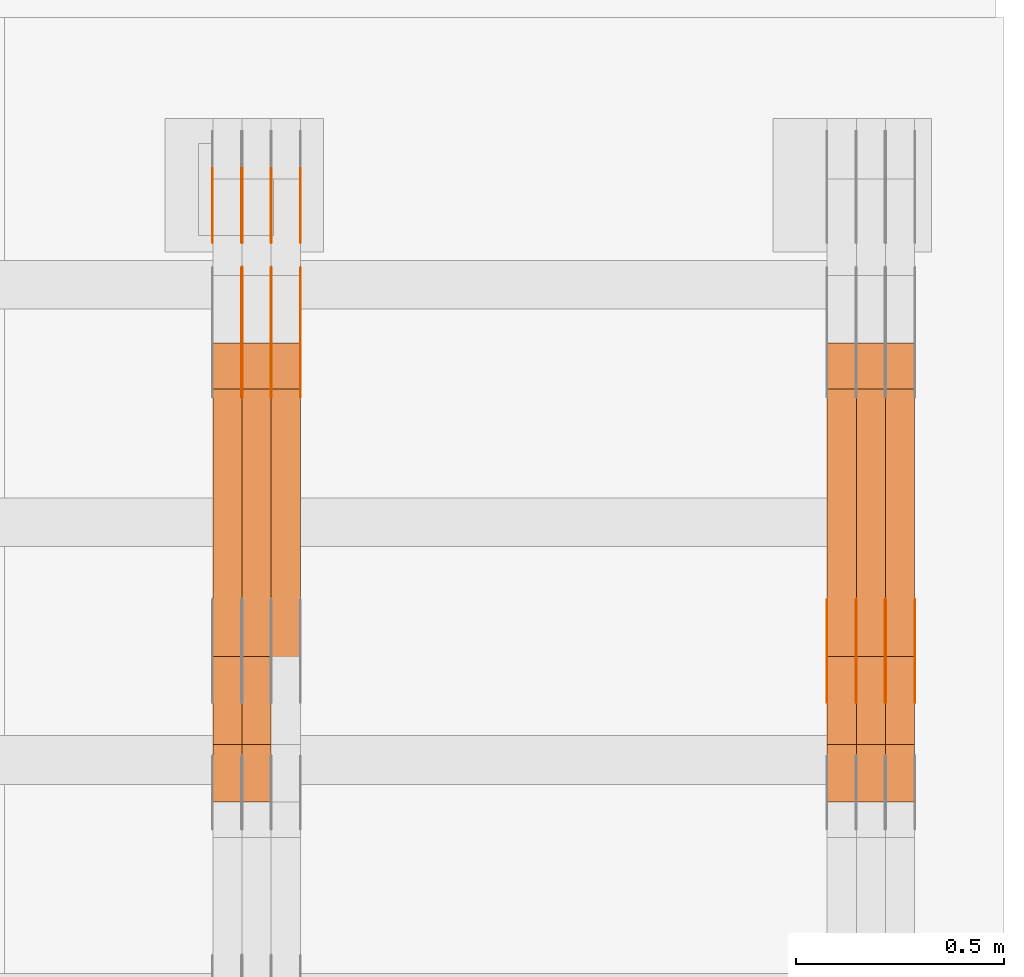
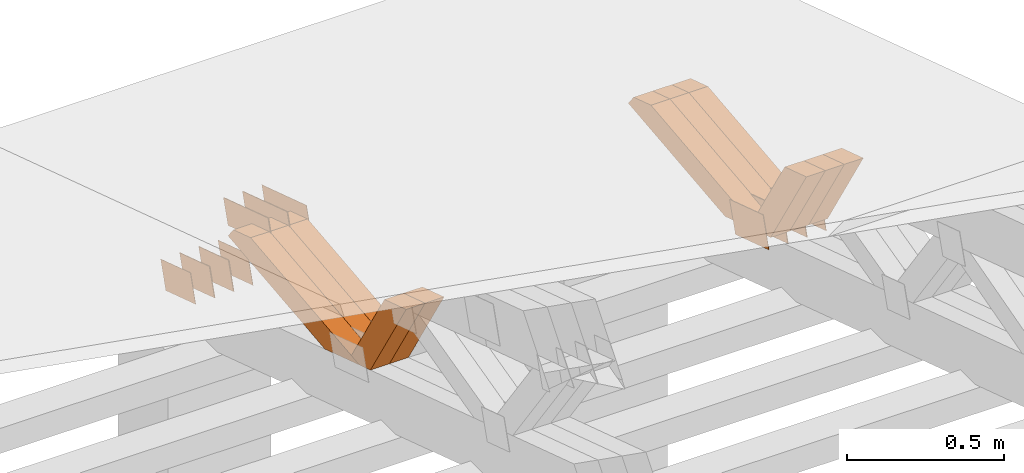
# One storey, part 375 of 385: 28 proxies.
"""IFC2X3 building model written with IfcOpenShell, lengths in millimetres."""

from ifc_helpers import new_model, entity, si_unit, converted_unit, derived_unit, direction, frame, origin, place, context, subcontext, project, spatial, polyline, outline, extrude, source, transform, mapped, material, type_object, type_shapes, element, save


model = new_model("IFC2X3")

# Units and contexts
model_context = context("Model", 3, precision=0.01, world=origin(), true_north=direction((6.12303176911189e-17, 1.0)))
body_context = subcontext(model_context, "Body", "Model", "MODEL_VIEW")
ifc_project = project(units=[si_unit("LENGTHUNIT", "METRE", prefix="MILLI"), si_unit("AREAUNIT", "SQUARE_METRE"), si_unit("VOLUMEUNIT", "CUBIC_METRE"), converted_unit("PLANEANGLEUNIT", "DEGREE", entity("IfcRatioMeasure", 0.0174532925199433), si_unit("PLANEANGLEUNIT", "RADIAN"), dimensions=[0, 0, 0, 0, 0, 0, 0]), si_unit("MASSUNIT", "GRAM", prefix="KILO"), derived_unit("MASSDENSITYUNIT", [(si_unit("MASSUNIT", "GRAM", prefix="KILO"), 1), (si_unit("LENGTHUNIT", "METRE"), -3)]), si_unit("TIMEUNIT", "SECOND"), si_unit("FREQUENCYUNIT", "HERTZ"), si_unit("THERMODYNAMICTEMPERATUREUNIT", "DEGREE_CELSIUS"), derived_unit("THERMALTRANSMITTANCEUNIT", [(si_unit("MASSUNIT", "GRAM", prefix="KILO"), 1), (si_unit("THERMODYNAMICTEMPERATUREUNIT", "KELVIN"), -1), (si_unit("TIMEUNIT", "SECOND"), -3)]), derived_unit("VOLUMETRICFLOWRATEUNIT", [(si_unit("LENGTHUNIT", "METRE"), 3), (si_unit("TIMEUNIT", "SECOND"), -1)]), si_unit("ELECTRICCURRENTUNIT", "AMPERE"), si_unit("ELECTRICVOLTAGEUNIT", "VOLT"), si_unit("POWERUNIT", "WATT"), si_unit("FORCEUNIT", "NEWTON", prefix="KILO"), si_unit("ILLUMINANCEUNIT", "LUX"), si_unit("LUMINOUSFLUXUNIT", "LUMEN"), si_unit("LUMINOUSINTENSITYUNIT", "CANDELA"), derived_unit("USERDEFINED", [(si_unit("MASSUNIT", "GRAM", prefix="KILO"), -1), (si_unit("LENGTHUNIT", "METRE"), -2), (si_unit("TIMEUNIT", "SECOND"), 3), (si_unit("LUMINOUSFLUXUNIT", "LUMEN"), 1)]), derived_unit("LINEARVELOCITYUNIT", [(si_unit("LENGTHUNIT", "METRE"), 1), (si_unit("TIMEUNIT", "SECOND"), -1)]), si_unit("PRESSUREUNIT", "PASCAL"), derived_unit("USERDEFINED", [(si_unit("LENGTHUNIT", "METRE"), -2), (si_unit("MASSUNIT", "GRAM", prefix="KILO"), 1), (si_unit("TIMEUNIT", "SECOND"), -2)])], contexts=[model_context])

# Site, building, storey
site_placement = place(None, origin())
site = spatial("IfcSite", under=ifc_project, at=site_placement, CompositionType="ELEMENT")
building_placement = place(site_placement, origin())
building = spatial("IfcBuilding", under=site, at=building_placement, CompositionType="ELEMENT")
storey_placement = place(building_placement, origin())
storey = spatial("IfcBuildingStorey", under=building, at=storey_placement, Name="Default", CompositionType="ELEMENT", Elevation=0.0)

# Proxies
ifc_material_1 = material(Name="IfcSurfaceStyle #607276")
building_element_proxy_type_1 = type_object("IfcBuildingElementProxyType", PredefinedType="NOTDEFINED", material=ifc_material_1)
shared_shape_1 = source(origin(), body_context, "Body", "SweptSolid", [
    extrude(outline(polyline([(-112.50003853564, -60.0000121429077), (112.50002982902, -60.0000121429077), (112.500043250865, 60.0000121429077), (-112.500034544245, 60.0000121429077), (-112.50003853564, -60.0000121429077)])), frame((112.500056021398, 60.0000121429077, 0.0), z_axis=(0.0, 0.0, 1.0), x_axis=(-1.0, 0.0, 0.0)), (0.0, 0.0, 1.0), 1.3),
])
type_shapes(building_element_proxy_type_1, [shared_shape_1])
proxy_1_placement = place(building_placement, frame((49861.3, 25310.2182710494, 430.675738123044), z_axis=(-1.0, 0.0, 0.0), x_axis=(0.0, -0.951056516295124, 0.309016994375039)))
element("IfcBuildingElementProxy", 1, at=proxy_1_placement, inside=storey, type_object=building_element_proxy_type_1, material=ifc_material_1, context=body_context, shape_type="MappedRepresentation", body=[
    mapped(shared_shape_1, transform((0.0, 0.0, 0.0), scale=1.0)),
])
ifc_material_2 = material(Name="IfcSurfaceStyle #607219")
building_element_proxy_type_2 = type_object("IfcBuildingElementProxyType", PredefinedType="NOTDEFINED", material=ifc_material_2)
shared_shape_2 = source(origin(), body_context, "Body", "SweptSolid", [
    extrude(outline(polyline([(-112.50003853564, -60.0000121429077), (112.50002982902, -60.0000121429077), (112.500043250865, 60.0000121429077), (-112.500034544245, 60.0000121429077), (-112.50003853564, -60.0000121429077)])), frame((112.500056021398, 60.0000121429077, 0.0), z_axis=(0.0, 0.0, 1.0), x_axis=(-1.0, 0.0, 0.0)), (0.0, 0.0, 1.0), 1.3),
])
type_shapes(building_element_proxy_type_2, [shared_shape_2])
proxy_2_placement = place(building_placement, frame((49790.0, 25310.2182710494, 430.675738123044), z_axis=(-1.0, 0.0, 0.0), x_axis=(0.0, -0.951056516295124, 0.309016994375039)))
element("IfcBuildingElementProxy", 2, at=proxy_2_placement, inside=storey, type_object=building_element_proxy_type_2, material=ifc_material_2, context=body_context, shape_type="MappedRepresentation", body=[
    mapped(shared_shape_2, transform((0.0, 0.0, 0.0), scale=1.0)),
])
ifc_material_3 = material(Name="IfcSurfaceStyle #607162")
building_element_proxy_type_3 = type_object("IfcBuildingElementProxyType", PredefinedType="NOTDEFINED", material=ifc_material_3)
shared_shape_3 = source(origin(), body_context, "Body", "SweptSolid", [
    extrude(outline(polyline([(-112.50003853564, -60.0000121429077), (112.50002982902, -60.0000121429077), (112.500043250865, 60.0000121429077), (-112.500034544245, 60.0000121429077), (-112.50003853564, -60.0000121429077)])), frame((112.500056021398, 60.0000121429077, 0.0), z_axis=(0.0, 0.0, 1.0), x_axis=(-1.0, 0.0, 0.0)), (0.0, 0.0, 1.0), 1.3),
])
type_shapes(building_element_proxy_type_3, [shared_shape_3])
proxy_3_placement = place(building_placement, frame((49791.3, 25310.2182710494, 430.675738123044), z_axis=(-1.0, 0.0, 0.0), x_axis=(0.0, -0.951056516295124, 0.309016994375039)))
element("IfcBuildingElementProxy", 3, at=proxy_3_placement, inside=storey, type_object=building_element_proxy_type_3, material=ifc_material_3, context=body_context, shape_type="MappedRepresentation", body=[
    mapped(shared_shape_3, transform((0.0, 0.0, 0.0), scale=1.0)),
])
ifc_material_4 = material(Name="IfcSurfaceStyle #607105")
building_element_proxy_type_4 = type_object("IfcBuildingElementProxyType", PredefinedType="NOTDEFINED", material=ifc_material_4)
shared_shape_4 = source(origin(), body_context, "Body", "SweptSolid", [
    extrude(outline(polyline([(-112.50003853564, -60.0000121429077), (112.50002982902, -60.0000121429077), (112.500043250865, 60.0000121429077), (-112.500034544245, 60.0000121429077), (-112.50003853564, -60.0000121429077)])), frame((112.500056021398, 60.0000121429077, 0.0), z_axis=(0.0, 0.0, 1.0), x_axis=(-1.0, 0.0, 0.0)), (0.0, 0.0, 1.0), 1.29999999999998),
])
type_shapes(building_element_proxy_type_4, [shared_shape_4])
proxy_4_placement = place(building_placement, frame((49720.0, 25310.2182710494, 430.675738123044), z_axis=(-1.0, 0.0, 0.0), x_axis=(0.0, -0.951056516295124, 0.309016994375039)))
element("IfcBuildingElementProxy", 4, at=proxy_4_placement, inside=storey, type_object=building_element_proxy_type_4, material=ifc_material_4, context=body_context, shape_type="MappedRepresentation", body=[
    mapped(shared_shape_4, transform((0.0, 0.0, 0.0), scale=1.0)),
])
ifc_material_5 = material(Name="IfcSurfaceStyle #607048")
building_element_proxy_type_5 = type_object("IfcBuildingElementProxyType", PredefinedType="NOTDEFINED", material=ifc_material_5)
shared_shape_5 = source(origin(), body_context, "Body", "SweptSolid", [
    extrude(outline(polyline([(-112.50003853564, -60.0000121429077), (112.50002982902, -60.0000121429077), (112.500043250865, 60.0000121429077), (-112.500034544245, 60.0000121429077), (-112.50003853564, -60.0000121429077)])), frame((112.500056021398, 60.0000121429077, 0.0), z_axis=(0.0, 0.0, 1.0), x_axis=(-1.0, 0.0, 0.0)), (0.0, 0.0, 1.0), 1.29999999999998),
])
type_shapes(building_element_proxy_type_5, [shared_shape_5])
proxy_5_placement = place(building_placement, frame((49721.3, 25310.2182710494, 430.675738123044), z_axis=(-1.0, 0.0, 0.0), x_axis=(0.0, -0.951056516295124, 0.309016994375039)))
element("IfcBuildingElementProxy", 5, at=proxy_5_placement, inside=storey, type_object=building_element_proxy_type_5, material=ifc_material_5, context=body_context, shape_type="MappedRepresentation", body=[
    mapped(shared_shape_5, transform((0.0, 0.0, 0.0), scale=1.0)),
])
ifc_material_6 = material(Name="IfcSurfaceStyle #606991")
building_element_proxy_type_6 = type_object("IfcBuildingElementProxyType", PredefinedType="NOTDEFINED", material=ifc_material_6)
shared_shape_6 = source(origin(), body_context, "Body", "SweptSolid", [
    extrude(outline(polyline([(-112.50003853564, -60.0000121429077), (112.50002982902, -60.0000121429077), (112.500043250865, 60.0000121429077), (-112.500034544245, 60.0000121429077), (-112.50003853564, -60.0000121429077)])), frame((112.500056021398, 60.0000121429077, 0.0), z_axis=(0.0, 0.0, 1.0), x_axis=(-1.0, 0.0, 0.0)), (0.0, 0.0, 1.0), 1.29999999999999),
])
type_shapes(building_element_proxy_type_6, [shared_shape_6])
proxy_6_placement = place(building_placement, frame((49650.0, 25310.2182710494, 430.675738123044), z_axis=(-1.0, 0.0, 0.0), x_axis=(0.0, -0.951056516295124, 0.309016994375039)))
element("IfcBuildingElementProxy", 6, at=proxy_6_placement, inside=storey, type_object=building_element_proxy_type_6, material=ifc_material_6, context=body_context, shape_type="MappedRepresentation", body=[
    mapped(shared_shape_6, transform((0.0, 0.0, 0.0), scale=1.0)),
])
ifc_material_7 = material(Name="IfcSurfaceStyle #595234")
building_element_proxy_type_7 = type_object("IfcBuildingElementProxyType", Name="T2-W31 595232", PredefinedType="NOTDEFINED", material=ifc_material_7)
shared_shape_7 = source(origin(), body_context, "Body", "SweptSolid", [
    extrude(outline(polyline([(-201.245318299844, -47.5000121670808), (204.413774229459, -47.5000121670808), (182.034306640891, 5.35692244583164e-05), (126.70380769348, 47.4999853824686), (-311.906570263987, 47.4999853824686), (-201.245318299844, -47.5000121670808)])), frame((204.413774229459, 47.5002684334588, 0.0), z_axis=(0.0, 0.0, 1.0), x_axis=(-1.0, 0.0, 0.0)), (0.0, 0.0, 1.0), 70.0),
])
type_shapes(building_element_proxy_type_7, [shared_shape_7])
proxy_7_placement = place(building_placement, frame((49860.0, 25127.5652647985, 487.27008059185), z_axis=(-1.0, 0.0, 0.0), x_axis=(0.0, -0.520333970303023, 0.853962855953755)))
element("IfcBuildingElementProxy", 7, at=proxy_7_placement, inside=storey, type_object=building_element_proxy_type_7, material=ifc_material_7, Name="T2-W31", context=body_context, shape_type="MappedRepresentation", body=[
    mapped(shared_shape_7, transform((0.0, 0.0, 0.0), scale=1.0)),
])
ifc_material_8 = material(Name="IfcSurfaceStyle #595168")
building_element_proxy_type_8 = type_object("IfcBuildingElementProxyType", Name="T2-W31 595166", PredefinedType="NOTDEFINED", material=ifc_material_8)
shared_shape_8 = source(origin(), body_context, "Body", "SweptSolid", [
    extrude(outline(polyline([(-201.245318299844, -47.5000121670808), (204.413774229459, -47.5000121670808), (182.034306640891, 5.35692244583164e-05), (126.70380769348, 47.4999853824686), (-311.906570263987, 47.4999853824686), (-201.245318299844, -47.5000121670808)])), frame((204.413774229459, 47.5002684334588, 0.0), z_axis=(0.0, 0.0, 1.0), x_axis=(-1.0, 0.0, 0.0)), (0.0, 0.0, 1.0), 70.0),
])
type_shapes(building_element_proxy_type_8, [shared_shape_8])
proxy_8_placement = place(building_placement, frame((49790.0, 25127.5652647985, 487.27008059185), z_axis=(-1.0, 0.0, 0.0), x_axis=(0.0, -0.520333970303023, 0.853962855953755)))
element("IfcBuildingElementProxy", 8, at=proxy_8_placement, inside=storey, type_object=building_element_proxy_type_8, material=ifc_material_8, Name="T2-W31", context=body_context, shape_type="MappedRepresentation", body=[
    mapped(shared_shape_8, transform((0.0, 0.0, 0.0), scale=1.0)),
])
ifc_material_9 = material(Name="IfcSurfaceStyle #595102")
building_element_proxy_type_9 = type_object("IfcBuildingElementProxyType", Name="T2-W31 595100", PredefinedType="NOTDEFINED", material=ifc_material_9)
shared_shape_9 = source(origin(), body_context, "Body", "SweptSolid", [
    extrude(outline(polyline([(-201.245318299844, -47.5000121670808), (204.413774229459, -47.5000121670808), (182.034306640891, 5.35692244583164e-05), (126.70380769348, 47.4999853824686), (-311.906570263987, 47.4999853824686), (-201.245318299844, -47.5000121670808)])), frame((204.413774229459, 47.5002684334588, 0.0), z_axis=(0.0, 0.0, 1.0), x_axis=(-1.0, 0.0, 0.0)), (0.0, 0.0, 1.0), 70.0),
])
type_shapes(building_element_proxy_type_9, [shared_shape_9])
proxy_9_placement = place(building_placement, frame((49720.0, 25127.5652647985, 487.27008059185), z_axis=(-1.0, 0.0, 0.0), x_axis=(0.0, -0.520333970303023, 0.853962855953755)))
element("IfcBuildingElementProxy", 9, at=proxy_9_placement, inside=storey, type_object=building_element_proxy_type_9, material=ifc_material_9, Name="T2-W31", context=body_context, shape_type="MappedRepresentation", body=[
    mapped(shared_shape_9, transform((0.0, 0.0, 0.0), scale=1.0)),
])
ifc_material_10 = material(Name="IfcSurfaceStyle #594838")
building_element_proxy_type_10 = type_object("IfcBuildingElementProxyType", Name="T2-W4 594836", PredefinedType="NOTDEFINED", material=ifc_material_10)
shared_shape_10 = source(origin(), body_context, "Body", "SweptSolid", [
    extrude(outline(polyline([(-510.077325435179, -47.4999981284922), (188.854793418912, -47.4999981284922), (294.906688207675, 1.67015383116809e-05), (324.289382923648, 47.499989777723), (-297.973539115057, 47.4999897777231), (-510.077325435179, -47.4999981284922)])), frame((324.289382923648, 47.5000278316275, 0.0), z_axis=(0.0, 0.0, 1.0), x_axis=(-1.0, 0.0, 0.0)), (0.0, 0.0, 1.0), 70.0),
])
type_shapes(building_element_proxy_type_10, [shared_shape_10])
proxy_10_placement = place(building_placement, frame((49860.0, 25996.2241251556, 525.69905884318), z_axis=(-1.0, 0.0, 0.0), x_axis=(0.0, -0.994287125203057, -0.106738524701444)))
element("IfcBuildingElementProxy", 10, at=proxy_10_placement, inside=storey, type_object=building_element_proxy_type_10, material=ifc_material_10, Name="T2-W4", context=body_context, shape_type="MappedRepresentation", body=[
    mapped(shared_shape_10, transform((0.0, 0.0, 0.0), scale=1.0)),
])
ifc_material_11 = material(Name="IfcSurfaceStyle #594772")
building_element_proxy_type_11 = type_object("IfcBuildingElementProxyType", Name="T2-W4 594770", PredefinedType="NOTDEFINED", material=ifc_material_11)
shared_shape_11 = source(origin(), body_context, "Body", "SweptSolid", [
    extrude(outline(polyline([(-510.077325435179, -47.4999981284922), (188.854793418912, -47.4999981284922), (294.906688207675, 1.67015383116809e-05), (324.289382923648, 47.499989777723), (-297.973539115057, 47.4999897777231), (-510.077325435179, -47.4999981284922)])), frame((324.289382923648, 47.5000278316275, 0.0), z_axis=(0.0, 0.0, 1.0), x_axis=(-1.0, 0.0, 0.0)), (0.0, 0.0, 1.0), 70.0),
])
type_shapes(building_element_proxy_type_11, [shared_shape_11])
proxy_11_placement = place(building_placement, frame((49790.0, 25996.2241251556, 525.69905884318), z_axis=(-1.0, 0.0, 0.0), x_axis=(0.0, -0.994287125203057, -0.106738524701444)))
element("IfcBuildingElementProxy", 11, at=proxy_11_placement, inside=storey, type_object=building_element_proxy_type_11, material=ifc_material_11, Name="T2-W4", context=body_context, shape_type="MappedRepresentation", body=[
    mapped(shared_shape_11, transform((0.0, 0.0, 0.0), scale=1.0)),
])
ifc_material_12 = material(Name="IfcSurfaceStyle #594706")
building_element_proxy_type_12 = type_object("IfcBuildingElementProxyType", Name="T2-W4 594704", PredefinedType="NOTDEFINED", material=ifc_material_12)
shared_shape_12 = source(origin(), body_context, "Body", "SweptSolid", [
    extrude(outline(polyline([(-510.077325435179, -47.4999981284922), (188.854793418912, -47.4999981284922), (294.906688207675, 1.67015383116809e-05), (324.289382923648, 47.499989777723), (-297.973539115057, 47.4999897777231), (-510.077325435179, -47.4999981284922)])), frame((324.289382923648, 47.5000278316275, 0.0), z_axis=(0.0, 0.0, 1.0), x_axis=(-1.0, 0.0, 0.0)), (0.0, 0.0, 1.0), 70.0),
])
type_shapes(building_element_proxy_type_12, [shared_shape_12])
proxy_12_placement = place(building_placement, frame((49720.0, 25996.2241251556, 525.69905884318), z_axis=(-1.0, 0.0, 0.0), x_axis=(0.0, -0.994287125203057, -0.106738524701444)))
element("IfcBuildingElementProxy", 12, at=proxy_12_placement, inside=storey, type_object=building_element_proxy_type_12, material=ifc_material_12, Name="T2-W4", context=body_context, shape_type="MappedRepresentation", body=[
    mapped(shared_shape_12, transform((0.0, 0.0, 0.0), scale=1.0)),
])
ifc_material_13 = material(Name="IfcSurfaceStyle #584814")
building_element_proxy_type_13 = type_object("IfcBuildingElementProxyType", PredefinedType="NOTDEFINED", material=ifc_material_13)
shared_shape_13 = source(origin(), body_context, "Body", "SweptSolid", [
    extrude(outline(polyline([(-100.000024997547, -54.0000105875654), (100.000088940899, -54.0000105875654), (99.9999100805868, 54.0000105875654), (-99.9999740239394, 54.0000105875654), (-100.000024997547, -54.0000105875654)])), frame((100.000088940899, 54.0000474633838, 0.0), z_axis=(0.0, 0.0, 1.0), x_axis=(-1.0, 0.0, 0.0)), (0.0, 0.0, 1.0), 1.3),
])
type_shapes(building_element_proxy_type_13, [shared_shape_13])
proxy_13_placement = place(building_placement, frame((48386.3, 26390.6212638563, 73.3227520411355), z_axis=(-1.0, 0.0, 0.0), x_axis=(0.0, -0.951056516295124, 0.309016994375039)))
element("IfcBuildingElementProxy", 13, at=proxy_13_placement, inside=storey, type_object=building_element_proxy_type_13, material=ifc_material_13, context=body_context, shape_type="MappedRepresentation", body=[
    mapped(shared_shape_13, transform((0.0, 0.0, 0.0), scale=1.0)),
])
ifc_material_14 = material(Name="IfcSurfaceStyle #584757")
building_element_proxy_type_14 = type_object("IfcBuildingElementProxyType", PredefinedType="NOTDEFINED", material=ifc_material_14)
shared_shape_14 = source(origin(), body_context, "Body", "SweptSolid", [
    extrude(outline(polyline([(-100.000024997547, -54.0000105875654), (100.000088940899, -54.0000105875654), (99.9999100805868, 54.0000105875654), (-99.9999740239394, 54.0000105875654), (-100.000024997547, -54.0000105875654)])), frame((100.000088940899, 54.0000474633838, 0.0), z_axis=(0.0, 0.0, 1.0), x_axis=(-1.0, 0.0, 0.0)), (0.0, 0.0, 1.0), 1.3),
])
type_shapes(building_element_proxy_type_14, [shared_shape_14])
proxy_14_placement = place(building_placement, frame((48315.0, 26390.6212638563, 73.3227520411355), z_axis=(-1.0, 0.0, 0.0), x_axis=(0.0, -0.951056516295124, 0.309016994375039)))
element("IfcBuildingElementProxy", 14, at=proxy_14_placement, inside=storey, type_object=building_element_proxy_type_14, material=ifc_material_14, context=body_context, shape_type="MappedRepresentation", body=[
    mapped(shared_shape_14, transform((0.0, 0.0, 0.0), scale=1.0)),
])
ifc_material_15 = material(Name="IfcSurfaceStyle #584700")
building_element_proxy_type_15 = type_object("IfcBuildingElementProxyType", PredefinedType="NOTDEFINED", material=ifc_material_15)
shared_shape_15 = source(origin(), body_context, "Body", "SweptSolid", [
    extrude(outline(polyline([(-100.000024997547, -54.0000105875654), (100.000088940899, -54.0000105875654), (99.9999100805868, 54.0000105875654), (-99.9999740239394, 54.0000105875654), (-100.000024997547, -54.0000105875654)])), frame((100.000088940899, 54.0000474633838, 0.0), z_axis=(0.0, 0.0, 1.0), x_axis=(-1.0, 0.0, 0.0)), (0.0, 0.0, 1.0), 1.3),
])
type_shapes(building_element_proxy_type_15, [shared_shape_15])
proxy_15_placement = place(building_placement, frame((48316.3, 26390.6212638563, 73.3227520411355), z_axis=(-1.0, 0.0, 0.0), x_axis=(0.0, -0.951056516295124, 0.309016994375039)))
element("IfcBuildingElementProxy", 15, at=proxy_15_placement, inside=storey, type_object=building_element_proxy_type_15, material=ifc_material_15, context=body_context, shape_type="MappedRepresentation", body=[
    mapped(shared_shape_15, transform((0.0, 0.0, 0.0), scale=1.0)),
])
ifc_material_16 = material(Name="IfcSurfaceStyle #584643")
building_element_proxy_type_16 = type_object("IfcBuildingElementProxyType", PredefinedType="NOTDEFINED", material=ifc_material_16)
shared_shape_16 = source(origin(), body_context, "Body", "SweptSolid", [
    extrude(outline(polyline([(-100.000024997547, -54.0000105875654), (100.000088940899, -54.0000105875654), (99.9999100805868, 54.0000105875654), (-99.9999740239394, 54.0000105875654), (-100.000024997547, -54.0000105875654)])), frame((100.000088940899, 54.0000474633838, 0.0), z_axis=(0.0, 0.0, 1.0), x_axis=(-1.0, 0.0, 0.0)), (0.0, 0.0, 1.0), 1.29999999999998),
])
type_shapes(building_element_proxy_type_16, [shared_shape_16])
proxy_16_placement = place(building_placement, frame((48245.0, 26390.6212638563, 73.3227520411355), z_axis=(-1.0, 0.0, 0.0), x_axis=(0.0, -0.951056516295124, 0.309016994375039)))
element("IfcBuildingElementProxy", 16, at=proxy_16_placement, inside=storey, type_object=building_element_proxy_type_16, material=ifc_material_16, context=body_context, shape_type="MappedRepresentation", body=[
    mapped(shared_shape_16, transform((0.0, 0.0, 0.0), scale=1.0)),
])
ifc_material_17 = material(Name="IfcSurfaceStyle #584586")
building_element_proxy_type_17 = type_object("IfcBuildingElementProxyType", PredefinedType="NOTDEFINED", material=ifc_material_17)
shared_shape_17 = source(origin(), body_context, "Body", "SweptSolid", [
    extrude(outline(polyline([(-100.000024997547, -54.0000105875654), (100.000088940899, -54.0000105875654), (99.9999100805868, 54.0000105875654), (-99.9999740239394, 54.0000105875654), (-100.000024997547, -54.0000105875654)])), frame((100.000088940899, 54.0000474633838, 0.0), z_axis=(0.0, 0.0, 1.0), x_axis=(-1.0, 0.0, 0.0)), (0.0, 0.0, 1.0), 1.29999999999998),
])
type_shapes(building_element_proxy_type_17, [shared_shape_17])
proxy_17_placement = place(building_placement, frame((48246.3, 26390.6212638563, 73.3227520411355), z_axis=(-1.0, 0.0, 0.0), x_axis=(0.0, -0.951056516295124, 0.309016994375039)))
element("IfcBuildingElementProxy", 17, at=proxy_17_placement, inside=storey, type_object=building_element_proxy_type_17, material=ifc_material_17, context=body_context, shape_type="MappedRepresentation", body=[
    mapped(shared_shape_17, transform((0.0, 0.0, 0.0), scale=1.0)),
])
ifc_material_18 = material(Name="IfcSurfaceStyle #584529")
building_element_proxy_type_18 = type_object("IfcBuildingElementProxyType", PredefinedType="NOTDEFINED", material=ifc_material_18)
shared_shape_18 = source(origin(), body_context, "Body", "SweptSolid", [
    extrude(outline(polyline([(-100.000024997547, -54.0000105875654), (100.000088940899, -54.0000105875654), (99.9999100805868, 54.0000105875654), (-99.9999740239394, 54.0000105875654), (-100.000024997547, -54.0000105875654)])), frame((100.000088940899, 54.0000474633838, 0.0), z_axis=(0.0, 0.0, 1.0), x_axis=(-1.0, 0.0, 0.0)), (0.0, 0.0, 1.0), 1.29999999999999),
])
type_shapes(building_element_proxy_type_18, [shared_shape_18])
proxy_18_placement = place(building_placement, frame((48175.0, 26390.6212638563, 73.3227520411355), z_axis=(-1.0, 0.0, 0.0), x_axis=(0.0, -0.951056516295124, 0.309016994375039)))
element("IfcBuildingElementProxy", 18, at=proxy_18_placement, inside=storey, type_object=building_element_proxy_type_18, material=ifc_material_18, context=body_context, shape_type="MappedRepresentation", body=[
    mapped(shared_shape_18, transform((0.0, 0.0, 0.0), scale=1.0)),
])
ifc_material_19 = material(Name="IfcSurfaceStyle #572160")
building_element_proxy_type_19 = type_object("IfcBuildingElementProxyType", PredefinedType="NOTDEFINED", material=ifc_material_19)
shared_shape_19 = source(origin(), body_context, "Body", "SweptSolid", [
    extrude(outline(polyline([(-149.999901061401, -48.0000057587028), (150.000035297123, -48.0000057587028), (149.999910491851, 48.0000057587028), (-150.000044727574, 48.0000057587028), (-149.999901061401, -48.0000057587028)])), frame((150.000035297123, 48.0000632585775, 0.0), z_axis=(0.0, 0.0, 1.0), x_axis=(-1.0, 0.0, 0.0)), (0.0, 0.0, 1.0), 1.29999999999999),
])
type_shapes(building_element_proxy_type_19, [shared_shape_19])
proxy_19_placement = place(building_placement, frame((48386.3, 26115.0176968219, 469.58296924555), z_axis=(-1.0, 0.0, 0.0), x_axis=(0.0, -0.951056516295154, 0.309016994374948)))
element("IfcBuildingElementProxy", 19, at=proxy_19_placement, inside=storey, type_object=building_element_proxy_type_19, material=ifc_material_19, context=body_context, shape_type="MappedRepresentation", body=[
    mapped(shared_shape_19, transform((0.0, 0.0, 0.0), scale=1.0)),
])
ifc_material_20 = material(Name="IfcSurfaceStyle #572103")
building_element_proxy_type_20 = type_object("IfcBuildingElementProxyType", PredefinedType="NOTDEFINED", material=ifc_material_20)
shared_shape_20 = source(origin(), body_context, "Body", "SweptSolid", [
    extrude(outline(polyline([(-149.999901061401, -48.0000057587028), (150.000035297123, -48.0000057587028), (149.999910491851, 48.0000057587028), (-150.000044727574, 48.0000057587028), (-149.999901061401, -48.0000057587028)])), frame((150.000035297123, 48.0000632585775, 0.0), z_axis=(0.0, 0.0, 1.0), x_axis=(-1.0, 0.0, 0.0)), (0.0, 0.0, 1.0), 1.29999999999999),
])
type_shapes(building_element_proxy_type_20, [shared_shape_20])
proxy_20_placement = place(building_placement, frame((48315.0, 26115.0176968219, 469.58296924555), z_axis=(-1.0, 0.0, 0.0), x_axis=(0.0, -0.951056516295154, 0.309016994374948)))
element("IfcBuildingElementProxy", 20, at=proxy_20_placement, inside=storey, type_object=building_element_proxy_type_20, material=ifc_material_20, context=body_context, shape_type="MappedRepresentation", body=[
    mapped(shared_shape_20, transform((0.0, 0.0, 0.0), scale=1.0)),
])
ifc_material_21 = material(Name="IfcSurfaceStyle #572046")
building_element_proxy_type_21 = type_object("IfcBuildingElementProxyType", PredefinedType="NOTDEFINED", material=ifc_material_21)
shared_shape_21 = source(origin(), body_context, "Body", "SweptSolid", [
    extrude(outline(polyline([(-149.999901061401, -48.0000057587028), (150.000035297123, -48.0000057587028), (149.999910491851, 48.0000057587028), (-150.000044727574, 48.0000057587028), (-149.999901061401, -48.0000057587028)])), frame((150.000035297123, 48.0000632585775, 0.0), z_axis=(0.0, 0.0, 1.0), x_axis=(-1.0, 0.0, 0.0)), (0.0, 0.0, 1.0), 1.29999999999999),
])
type_shapes(building_element_proxy_type_21, [shared_shape_21])
proxy_21_placement = place(building_placement, frame((48316.3, 26115.0176968219, 469.58296924555), z_axis=(-1.0, 0.0, 0.0), x_axis=(0.0, -0.951056516295154, 0.309016994374948)))
element("IfcBuildingElementProxy", 21, at=proxy_21_placement, inside=storey, type_object=building_element_proxy_type_21, material=ifc_material_21, context=body_context, shape_type="MappedRepresentation", body=[
    mapped(shared_shape_21, transform((0.0, 0.0, 0.0), scale=1.0)),
])
ifc_material_22 = material(Name="IfcSurfaceStyle #571989")
building_element_proxy_type_22 = type_object("IfcBuildingElementProxyType", PredefinedType="NOTDEFINED", material=ifc_material_22)
shared_shape_22 = source(origin(), body_context, "Body", "SweptSolid", [
    extrude(outline(polyline([(-149.999901061401, -48.0000057587028), (150.000035297123, -48.0000057587028), (149.999910491851, 48.0000057587028), (-150.000044727574, 48.0000057587028), (-149.999901061401, -48.0000057587028)])), frame((150.000035297123, 48.0000632585775, 0.0), z_axis=(0.0, 0.0, 1.0), x_axis=(-1.0, 0.0, 0.0)), (0.0, 0.0, 1.0), 1.29999999999998),
])
type_shapes(building_element_proxy_type_22, [shared_shape_22])
proxy_22_placement = place(building_placement, frame((48245.0, 26115.0176968219, 469.58296924555), z_axis=(-1.0, 0.0, 0.0), x_axis=(0.0, -0.951056516295154, 0.309016994374948)))
element("IfcBuildingElementProxy", 22, at=proxy_22_placement, inside=storey, type_object=building_element_proxy_type_22, material=ifc_material_22, context=body_context, shape_type="MappedRepresentation", body=[
    mapped(shared_shape_22, transform((0.0, 0.0, 0.0), scale=1.0)),
])
ifc_material_23 = material(Name="IfcSurfaceStyle #571932")
building_element_proxy_type_23 = type_object("IfcBuildingElementProxyType", PredefinedType="NOTDEFINED", material=ifc_material_23)
shared_shape_23 = source(origin(), body_context, "Body", "SweptSolid", [
    extrude(outline(polyline([(-149.999901061401, -48.0000057587028), (150.000035297123, -48.0000057587028), (149.999910491851, 48.0000057587028), (-150.000044727574, 48.0000057587028), (-149.999901061401, -48.0000057587028)])), frame((150.000035297123, 48.0000632585775, 0.0), z_axis=(0.0, 0.0, 1.0), x_axis=(-1.0, 0.0, 0.0)), (0.0, 0.0, 1.0), 1.29999999999998),
])
type_shapes(building_element_proxy_type_23, [shared_shape_23])
proxy_23_placement = place(building_placement, frame((48246.3, 26115.0176968219, 469.58296924555), z_axis=(-1.0, 0.0, 0.0), x_axis=(0.0, -0.951056516295154, 0.309016994374948)))
element("IfcBuildingElementProxy", 23, at=proxy_23_placement, inside=storey, type_object=building_element_proxy_type_23, material=ifc_material_23, context=body_context, shape_type="MappedRepresentation", body=[
    mapped(shared_shape_23, transform((0.0, 0.0, 0.0), scale=1.0)),
])
ifc_material_24 = material(Name="IfcSurfaceStyle #560736")
building_element_proxy_type_24 = type_object("IfcBuildingElementProxyType", Name="T1-W31 560734", PredefinedType="NOTDEFINED", material=ifc_material_24)
shared_shape_24 = source(origin(), body_context, "Body", "SweptSolid", [
    extrude(outline(polyline([(-201.245318299844, -47.5000121670808), (204.413774229459, -47.5000121670808), (182.034306640891, 5.35692244583164e-05), (126.70380769348, 47.4999853824686), (-311.906570263987, 47.4999853824686), (-201.245318299844, -47.5000121670808)])), frame((204.413774229459, 47.5002684334588, 0.0), z_axis=(0.0, 0.0, 1.0), x_axis=(-1.0, 0.0, 0.0)), (0.0, 0.0, 1.0), 70.0),
])
type_shapes(building_element_proxy_type_24, [shared_shape_24])
proxy_24_placement = place(building_placement, frame((48315.0, 25127.5652647985, 487.27008059185), z_axis=(-1.0, 0.0, 0.0), x_axis=(0.0, -0.520333970303023, 0.853962855953755)))
element("IfcBuildingElementProxy", 24, at=proxy_24_placement, inside=storey, type_object=building_element_proxy_type_24, material=ifc_material_24, Name="T1-W31", context=body_context, shape_type="MappedRepresentation", body=[
    mapped(shared_shape_24, transform((0.0, 0.0, 0.0), scale=1.0)),
])
ifc_material_25 = material(Name="IfcSurfaceStyle #560670")
building_element_proxy_type_25 = type_object("IfcBuildingElementProxyType", Name="T1-W31 560668", PredefinedType="NOTDEFINED", material=ifc_material_25)
shared_shape_25 = source(origin(), body_context, "Body", "SweptSolid", [
    extrude(outline(polyline([(-201.245318299844, -47.5000121670808), (204.413774229459, -47.5000121670808), (182.034306640891, 5.35692244583164e-05), (126.70380769348, 47.4999853824686), (-311.906570263987, 47.4999853824686), (-201.245318299844, -47.5000121670808)])), frame((204.413774229459, 47.5002684334588, 0.0), z_axis=(0.0, 0.0, 1.0), x_axis=(-1.0, 0.0, 0.0)), (0.0, 0.0, 1.0), 70.0),
])
type_shapes(building_element_proxy_type_25, [shared_shape_25])
proxy_25_placement = place(building_placement, frame((48245.0, 25127.5652647985, 487.27008059185), z_axis=(-1.0, 0.0, 0.0), x_axis=(0.0, -0.520333970303023, 0.853962855953755)))
element("IfcBuildingElementProxy", 25, at=proxy_25_placement, inside=storey, type_object=building_element_proxy_type_25, material=ifc_material_25, Name="T1-W31", context=body_context, shape_type="MappedRepresentation", body=[
    mapped(shared_shape_25, transform((0.0, 0.0, 0.0), scale=1.0)),
])
ifc_material_26 = material(Name="IfcSurfaceStyle #560406")
building_element_proxy_type_26 = type_object("IfcBuildingElementProxyType", Name="T1-W4 560404", PredefinedType="NOTDEFINED", material=ifc_material_26)
shared_shape_26 = source(origin(), body_context, "Body", "SweptSolid", [
    extrude(outline(polyline([(-510.077325435179, -47.4999981284922), (188.854793418912, -47.4999981284922), (294.906688207675, 1.67015383116809e-05), (324.289382923648, 47.499989777723), (-297.973539115057, 47.4999897777231), (-510.077325435179, -47.4999981284922)])), frame((324.289382923648, 47.5000278316275, 0.0), z_axis=(0.0, 0.0, 1.0), x_axis=(-1.0, 0.0, 0.0)), (0.0, 0.0, 1.0), 70.0),
])
type_shapes(building_element_proxy_type_26, [shared_shape_26])
proxy_26_placement = place(building_placement, frame((48385.0, 25996.2241251556, 525.69905884318), z_axis=(-1.0, 0.0, 0.0), x_axis=(0.0, -0.994287125203057, -0.106738524701444)))
element("IfcBuildingElementProxy", 26, at=proxy_26_placement, inside=storey, type_object=building_element_proxy_type_26, material=ifc_material_26, Name="T1-W4", context=body_context, shape_type="MappedRepresentation", body=[
    mapped(shared_shape_26, transform((0.0, 0.0, 0.0), scale=1.0)),
])
ifc_material_27 = material(Name="IfcSurfaceStyle #560340")
building_element_proxy_type_27 = type_object("IfcBuildingElementProxyType", Name="T1-W4 560338", PredefinedType="NOTDEFINED", material=ifc_material_27)
shared_shape_27 = source(origin(), body_context, "Body", "SweptSolid", [
    extrude(outline(polyline([(-510.077325435179, -47.4999981284922), (188.854793418912, -47.4999981284922), (294.906688207675, 1.67015383116809e-05), (324.289382923648, 47.499989777723), (-297.973539115057, 47.4999897777231), (-510.077325435179, -47.4999981284922)])), frame((324.289382923648, 47.5000278316275, 0.0), z_axis=(0.0, 0.0, 1.0), x_axis=(-1.0, 0.0, 0.0)), (0.0, 0.0, 1.0), 70.0),
])
type_shapes(building_element_proxy_type_27, [shared_shape_27])
proxy_27_placement = place(building_placement, frame((48315.0, 25996.2241251556, 525.69905884318), z_axis=(-1.0, 0.0, 0.0), x_axis=(0.0, -0.994287125203057, -0.106738524701444)))
element("IfcBuildingElementProxy", 27, at=proxy_27_placement, inside=storey, type_object=building_element_proxy_type_27, material=ifc_material_27, Name="T1-W4", context=body_context, shape_type="MappedRepresentation", body=[
    mapped(shared_shape_27, transform((0.0, 0.0, 0.0), scale=1.0)),
])
ifc_material_28 = material(Name="IfcSurfaceStyle #560274")
building_element_proxy_type_28 = type_object("IfcBuildingElementProxyType", Name="T1-W4 560272", PredefinedType="NOTDEFINED", material=ifc_material_28)
shared_shape_28 = source(origin(), body_context, "Body", "SweptSolid", [
    extrude(outline(polyline([(-510.077325435179, -47.4999981284922), (188.854793418912, -47.4999981284922), (294.906688207675, 1.67015383116809e-05), (324.289382923648, 47.499989777723), (-297.973539115057, 47.4999897777231), (-510.077325435179, -47.4999981284922)])), frame((324.289382923648, 47.5000278316275, 0.0), z_axis=(0.0, 0.0, 1.0), x_axis=(-1.0, 0.0, 0.0)), (0.0, 0.0, 1.0), 70.0),
])
type_shapes(building_element_proxy_type_28, [shared_shape_28])
proxy_28_placement = place(building_placement, frame((48245.0, 25996.2241251556, 525.69905884318), z_axis=(-1.0, 0.0, 0.0), x_axis=(0.0, -0.994287125203057, -0.106738524701444)))
element("IfcBuildingElementProxy", 28, at=proxy_28_placement, inside=storey, type_object=building_element_proxy_type_28, material=ifc_material_28, Name="T1-W4", context=body_context, shape_type="MappedRepresentation", body=[
    mapped(shared_shape_28, transform((0.0, 0.0, 0.0), scale=1.0)),
])

save(model, "model.ifc")
